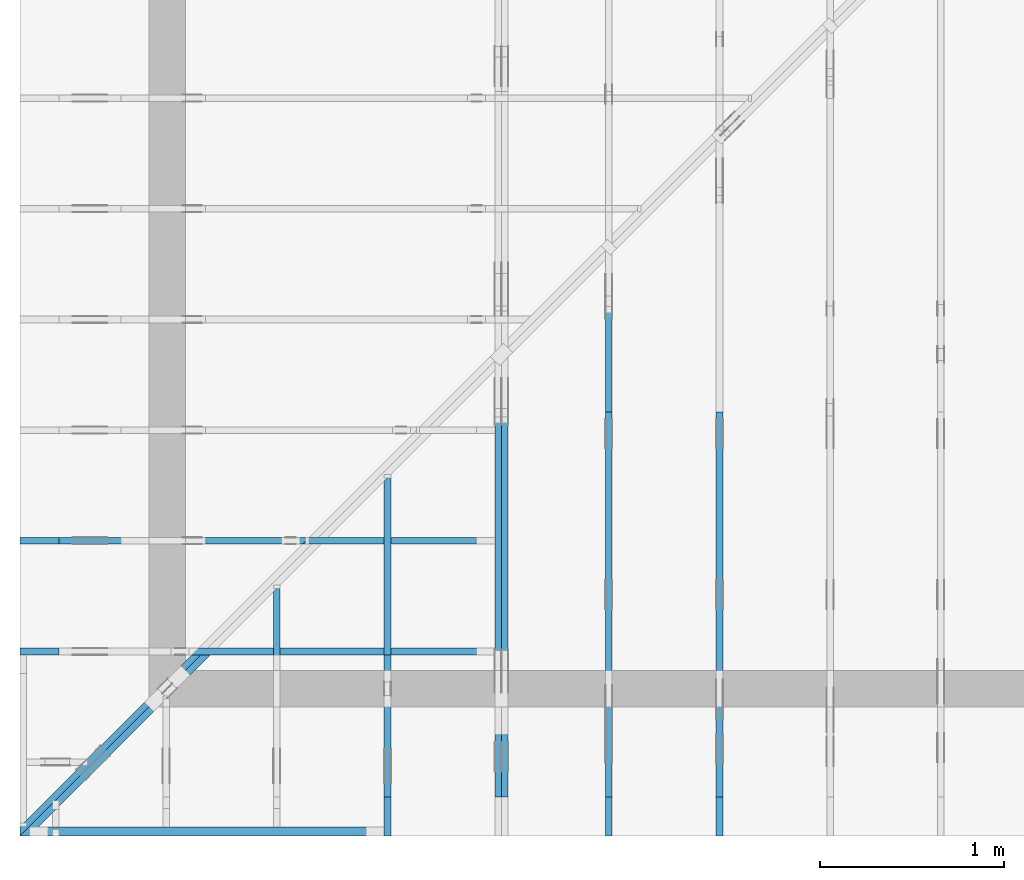
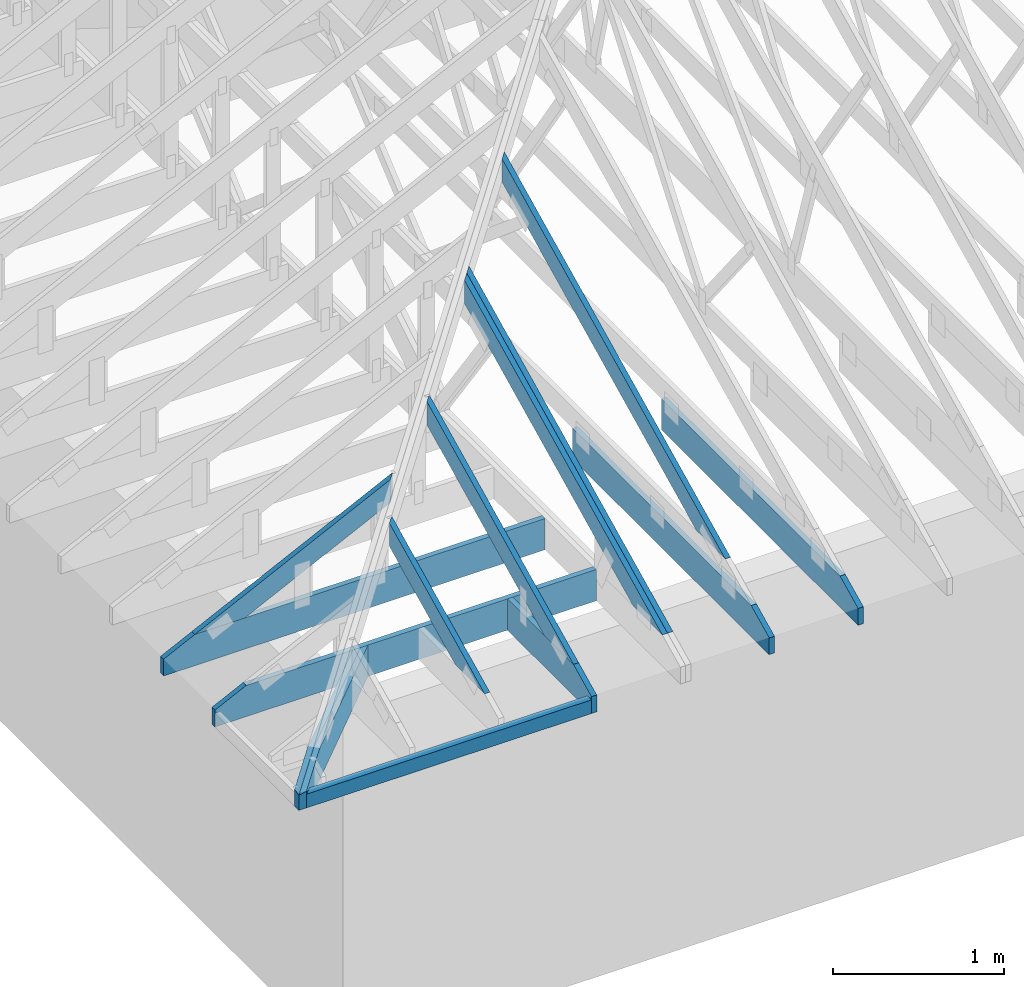
# One storey, part 2 of 159: 14 members, 9 elements without a shape of their own.
"""IFC2X3 building model written with IfcOpenShell, lengths in millimetres."""

from ifc_helpers import new_model, si_unit, frame, origin, origin_with_axes, origin_2d, place, context, project, spatial, faceted_brep, element, aggregate, save


model = new_model("IFC2X3")

# Units and contexts
model_context = context("Model", 3, precision=1e-05, world=origin())
plan_context = context("Plan", 2, precision=1e-05, world=origin_2d())
ifc_project = project(units=[si_unit("LENGTHUNIT", "METRE", prefix="MILLI"), si_unit("AREAUNIT", "SQUARE_METRE"), si_unit("VOLUMEUNIT", "CUBIC_METRE"), si_unit("SOLIDANGLEUNIT", "STERADIAN"), si_unit("PLANEANGLEUNIT", "RADIAN"), si_unit("MASSUNIT", "GRAM"), si_unit("TIMEUNIT", "SECOND"), si_unit("THERMODYNAMICTEMPERATUREUNIT", "DEGREE_CELSIUS"), si_unit("LUMINOUSINTENSITYUNIT", "LUMEN")], contexts=[model_context, plan_context])

# Site, building, storey
site_placement = place(None, origin_with_axes())
site = spatial("IfcSite", under=ifc_project, at=site_placement, CompositionType="ELEMENT")
building_placement = place(site_placement, origin_with_axes())
building = spatial("IfcBuilding", under=site, at=building_placement, Name="Plan 1", CompositionType="ELEMENT")
storey_placement = place(building_placement, origin_with_axes())
storey = spatial("IfcBuildingStorey", under=building, at=storey_placement, Name="Etasje 1", CompositionType="ELEMENT", Elevation=0.0)

# Assembly, member
assembly_1_placement = place(storey_placement, frame((-649.0883117545762, -699.9989301294845, 0.0), z_axis=(0.0, -1.0, 6.123031769111886e-17), x_axis=(1.0, 0.0, 0.0)))
assembly_1 = element("IfcElementAssembly", 1, at=assembly_1_placement, inside=storey, Name="uu1 (85)", AssemblyPlace="FACTORY", PredefinedType="TRUSS")
member_1_placement = place(assembly_1_placement, frame((1924.1105957031252, 98.00000038453275, -48.00000008178999), z_axis=(0.0, 0.0, 1.0), x_axis=(-1.0, 1.2246063538223773e-16, 0.0)))
member_1 = element("IfcMember", 2, at=member_1_placement, Name="uu1-U1", context=model_context, shape_type="Brep", body=[
    faceted_brep([(1876.110597873309, 98.000000384533, 2.2519742515214602e-06), (1924.1105957031252, 98.000000384533, 48.00000008179029), (1924.1105957031252, 3.845329956675414e-07, 48.00000008179029), (1876.1105978733092, 3.845329956675414e-07, 2.2519745925819734e-06), (2.2737367544323206e-13, 98.000000384533, 8.178999166830181e-08), (2.2737367544323206e-13, 98.000000384533, 48.00000008178999), (1924.1105957031252, 98.00000038453288, 48.00000008178999), (1876.1105957031252, 98.00000038453288, 8.178999166830181e-08), (2.2737367544323203e-13, 98.00000038453275, 8.178999166830181e-08), (1876.1105957031252, 98.00000038453275, 8.17902214179974e-08), (1876.110595703125, 3.845329956675414e-07, 8.17902214179974e-08), (2.2737367544323203e-13, 3.845329956675414e-07, 8.178999166830181e-08), (2.2543799104823847e-05, 0.0, 0.0), (2.2543799107762903e-05, -3.599185738505992e-31, 48.00000008178999), (2.2543799119764045e-05, 98.00000187990656, 48.00000092077057), (2.254379911682499e-05, 98.00000187990656, -7.348336802244504e-31), (1924.110595703125, 3.8453263095403277e-07, 48.00000008178999), (5.398778609579954e-31, 3.8453298439574193e-07, 48.00000008178999), (1.1020259538958945e-39, 3.845329814566867e-07, 8.178999166830181e-08), (1876.110595703125, 3.8453263683214327e-07, 8.178999166830181e-08), (1924.1105957031252, 98.000000384533, 48.00000008178999), (2.2737367544323206e-13, 98.000000384533, 48.00000008178999), (2.2737367544323206e-13, 3.8453276829386596e-07, 48.00000008178999), (1924.1105957031252, 3.8453276829386596e-07, 48.00000008178999)], [[[0, 1, 2, 3]], [[4, 5, 6, 7]], [[8, 9, 10, 11]], [[12, 13, 14, 15]], [[16, 17, 18, 19]], [[20, 21, 22, 23]]]),
])
aggregate(assembly_1, [member_1])

assembly_2_placement = place(storey_placement, frame((711.0222614047476, -663.9989301294845, 1.1021457184401395e-15), z_axis=(1.0, 1.6081428723391245e-16, 6.123031769111886e-17), x_axis=(-1.6081428723391245e-16, 1.0, 0.0)))
assembly_2 = element("IfcElementAssembly", 3, at=assembly_2_placement, inside=storey, Name="S11 (28)", AssemblyPlace="FACTORY", PredefinedType="TRUSS")
member_2_placement = place(assembly_2_placement, frame((240.06017447659758, 89.97845630520017, -36.000000217580876), z_axis=(0.0, 0.0, 1.0), x_axis=(0.898794046299167, 0.4383711467890774, 0.0)))
member_2 = element("IfcMember", 4, at=member_2_placement, Name="S11-O65", context=model_context, shape_type="Brep", body=[
    faceted_brep([(1278.3010010995256, 147.9999948190309, 36.000003247776476), (1206.1165771484377, 2.3277380023500882e-09, 36.000000217580805), (1166.0629072059032, 3.2351380241379957e-07, 0.0), (1238.247331156991, 147.99999514021712, 3.0301955575851025e-06), (9.693470434513074e-05, 147.99999999993207, 2.17580868877576e-07), (9.693470434513074e-05, 147.9999999999322, 36.00000021758087), (1278.3010002550168, 147.9999999999321, 36.00000021758087), (1238.247331279187, 147.999999999932, 2.17580868877576e-07), (1.594481932443159e-05, 148.00000000209985, 2.1758086887757795e-07), (1238.2473303979443, 148.00000000209985, 2.1758102051413083e-07), (1166.0629050439404, 0.0, 2.1758101167438024e-07), (303.44502326903785, 0.0, 2.1758090603764635e-07), (303.4450252214778, 1.1349783335390384e-09, 2.17580868877576e-07), (303.4450252214778, 1.1349783335390384e-09, 36.00000021758087), (5.3508346482544766e-05, 148.00000154207527, 36.00000021758087), (5.3508346482544766e-05, 148.00000154207524, 2.17580868877576e-07), (1206.1165762671362, 2.2746174269175835e-09, 36.00000021758087), (303.4450484045873, 2.2747832395108486e-09, 36.00000021758087), (303.4450484045873, 2.2747810352194118e-09, 2.17580868877576e-07), (1166.0629072913064, 2.2746225801227748e-09, 2.17580868877576e-07), (1278.3010025024416, 148.00000000232774, 36.00000021758087), (0.0, 148.00000000232774, 36.00000021758087), (303.445007324219, 1.1350778095220448e-09, 36.00000021758087), (1206.1165771484377, 1.1350778095220448e-09, 36.00000021758087)], [[[0, 1, 2, 3]], [[4, 5, 6, 7]], [[8, 9, 10, 11]], [[12, 13, 14, 15]], [[16, 17, 18, 19]], [[20, 21, 22, 23]]]),
])
aggregate(assembly_2, [member_2])

# Assembly, members
assembly_3_placement = place(storey_placement, frame((1311.0222614047498, -699.9989301294839, 1.1021457184401395e-15), z_axis=(1.0, -6.123031769111886e-17, 6.123031769111886e-17), x_axis=(6.123031769111886e-17, 1.0, 0.0)))
assembly_3 = element("IfcElementAssembly", 5, at=assembly_3_placement, inside=storey, Name="S12 (27)", AssemblyPlace="FACTORY", PredefinedType="TRUSS")
member_3_placement = place(assembly_3_placement, frame((276.06018082080396, 89.97845939889237, -36.00000021758392), z_axis=(0.0, 0.0, 1.0), x_axis=(0.898794046299167, 0.4383711467890774, 0.0)))
member_3 = element("IfcMember", 6, at=member_3_placement, Name="S12-O56", context=model_context, shape_type="Brep", body=[
    faceted_brep([(1945.8621583260756, 147.99999481908407, 36.00000324777977), (1873.677734375, 2.3747475097479764e-09, 36.00000021758376), (1833.6240644324685, 3.2355615076085087e-07, -3.410605131648481e-13), (1905.808488383544, 147.99999514026558, 3.0301958986456157e-06), (9.693470428828732e-05, 147.9999999999792, 2.175839171059124e-07), (9.693470428828732e-05, 147.99999999997908, 36.00000021758392), (1945.8621574815793, 147.9999999999794, 36.00000021758392), (1905.8084885057492, 147.9999999999795, 2.175839171059124e-07), (1.5944795677569346e-05, 148.00000000099197, 2.1758391710591436e-07), (1905.808487624483, 148.00000000099197, 2.1758415049243072e-07), (1833.6240622704795, 0.0, 2.1758414165268013e-07), (303.44496223385806, 0.0, 2.175839542659753e-07), (303.44501816315744, 1.65989888500917e-09, 2.175839171059124e-07), (303.44501816315744, 1.65989888500917e-09, 36.00000021758392), (4.645002616854299e-05, 148.00000154260016, 36.00000021758392), (4.645002616854299e-05, 148.00000154260016, 2.175839171059124e-07), (1873.677733493715, 2.3561247410074944e-09, 36.00000021758392), (303.4449873694475, 2.356413178557177e-09, 36.00000021758392), (303.4449873694475, 2.35641097426574e-09, 2.175839171059124e-07), (1833.624064517885, 2.3561298942126856e-09, 2.175839171059124e-07), (1945.862159729004, 148.0000000023748, 36.00000021758392), (0.0, 148.0000000023748, 36.00000021758392), (303.4450683593751, 1.659969939282746e-09, 36.00000021758392), (1873.677734375, 1.659969939282746e-09, 36.00000021758392)], [[[0, 1, 2, 3]], [[4, 5, 6, 7]], [[8, 9, 10, 11]], [[12, 13, 14, 15]], [[16, 17, 18, 19]], [[20, 21, 22, 23]]]),
])
member_4_placement = place(assembly_3_placement, frame((982.00634765625, 223.0, -36.0), z_axis=(0.0, 0.0, 1.0), x_axis=(-1.0, 1.2246063538223773e-16, 0.0)))
member_4 = element("IfcMember", 7, at=member_4_placement, Name="S12-U21", context=model_context, shape_type="Brep", body=[
    faceted_brep([(982.00634765625, 223.00000000001467, 36.0), (0.0, 223.00000000001467, 36.0), (0.0, 0.0, 36.0), (770.8250579833984, 0.0, 36.0), (982.006318893953, 102.99998474121105, 36.0), (0.0, 223.00000000001467, 0.0), (982.00634765625, 223.00000000001467, 1.20257121283375e-13), (982.006318893953, 102.99998474121105, 1.2025711776112584e-13), (770.8250579833984, 0.0, 9.439572636919721e-14), (0.0, 0.0, 0.0), (1.61055054377357e-05, 0.0, 0.0), (1.6105505439939992e-05, -2.6993892992798474e-31, 36.0), (1.6105505467248714e-05, 223.0, 36.0), (1.6105505465044423e-05, 223.0, -1.6721217180559947e-30), (770.8250519745052, -1.4159359023153358e-13, 1.3890631406147823e-29), (770.8250519745052, -1.393892987946533e-13, 36.0), (1.61055054377357e-05, 2.204286696927529e-15, 36.0), (1.61055054377357e-05, -4.739952749857793e-21, 2.9022881271468516e-37), (982.0063188939536, 102.99998597132787, 1.5480697785024754e-29), (982.0063188939536, 102.99998597132787, 36.0), (770.8250519745053, -5.684341886080802e-14, 36.0), (770.8250519745053, -5.684341886080802e-14, 1.1601225646455601e-29), (982.0062942062657, 223.00000000001467, -3.272759518476984e-21), (982.0062942062657, 223.00000000001467, 36.0), (982.0062942062657, 102.9999859713281, 36.0), (982.0062942062657, 102.9999859713281, -1.5116349691744716e-21), (1.61055054377357e-05, 223.0, 0.0), (1.61055054377357e-05, 223.0, 36.0), (982.00634765625, 223.00000000001475, 36.0), (982.00634765625, 223.00000000001478, 6.310887241768095e-30)], [[[0, 1, 2, 3, 4]], [[5, 6, 7, 8, 9]], [[10, 11, 12, 13]], [[14, 15, 16, 17]], [[18, 19, 20, 21]], [[22, 23, 24, 25]], [[26, 27, 28, 29]]]),
])
aggregate(assembly_3, [member_3, member_4])

# Assembly, member
assembly_4_placement = place(storey_placement, frame((-700.000000000007, 282.0074014212605, 1.1021457184401395e-15), z_axis=(0.0, -1.0, 6.123031769111886e-17), x_axis=(1.0, 0.0, 0.0)))
assembly_4 = element("IfcElementAssembly", 8, at=assembly_4_placement, inside=storey, Name="S8 (22)", AssemblyPlace="FACTORY", PredefinedType="TRUSS")
member_5_placement = place(assembly_4_placement, frame((2575.022261404756, 223.00000000093104, -36.0), z_axis=(0.0, 0.0, 1.0), x_axis=(-1.0, 1.2246063538223773e-16, 0.0)))
member_5 = element("IfcMember", 9, at=member_5_placement, Name="S8-U11", context=model_context, shape_type="Brep", body=[
    faceted_brep([(2575.022261404767, 223.00000000093135, 36.0), (4.4607881136471406e-05, 223.00000000093135, 36.0), (4.4607881136471406e-05, 9.310383575211745e-10, 36.0), (2363.8409717319046, 9.310383575211745e-10, 36.0), (2575.0222614047602, 103.00000000093135, 36.0), (4.4607881136471406e-05, 223.00000000093135, 5.462709467027625e-21), (2575.022261404767, 223.00000000093135, 3.1533886225503443e-13), (2575.0222614047602, 103.00000000093135, 3.1533886225503357e-13), (2363.8409717319046, 9.310383575211745e-10, 2.8947746734085526e-13), (4.4607881136471406e-05, 9.310383575211745e-10, 5.462709467027625e-21), (1.1401554882727804e-25, 9.310383575211745e-10, -6.981208276421509e-42), (2.2042914369942947e-15, 9.310383575211745e-10, 36.0), (2.9513013127233304e-14, 223.00000000093104, 36.0), (2.730872169035303e-14, 223.00000000093104, -1.6721217048386645e-30), (2363.8409657211487, 5.200890442812092e-13, -3.184521740901289e-29), (2363.8409657211487, 5.222933357180895e-13, 36.0), (8.67712118026388e-28, 9.310405618126114e-10, 36.0), (0.0, 9.310383575211745e-10, 0.0), (2575.0222614047602, 103.00000000064097, -5.048709793414476e-29), (2575.0222614047602, 103.00000000064097, 36.0), (2363.840965721148, 4.547473508864641e-13, 36.0), (2363.840965721148, 4.547473508864641e-13, -3.7865323450608567e-29), (2575.0222614047543, 223.00000000093135, -7.825500179792437e-28), (2575.0222614047543, 223.00000000093135, 36.0), (2575.0222614047543, 103.00000000064031, 36.0), (2575.0222614047543, 103.00000000064031, -3.534096855390133e-28), (0.0, 223.00000000093104, 0.0), (0.0, 223.00000000093104, 36.0), (2575.022261404767, 223.00000000093144, 36.0), (2575.022261404767, 223.00000000093146, 6.310887241768095e-30)], [[[0, 1, 2, 3, 4]], [[5, 6, 7, 8, 9]], [[10, 11, 12, 13]], [[14, 15, 16, 17]], [[18, 19, 20, 21]], [[22, 23, 24, 25]], [[26, 27, 28, 29]]]),
])
aggregate(assembly_4, [member_5])

# Assembly, members
assembly_5_placement = place(storey_placement, frame((-700.000000000007, 882.0074014212605, 1.1021457184401395e-15), z_axis=(0.0, -1.0, 6.123031769111886e-17), x_axis=(1.0, 0.0, 0.0)))
assembly_5 = element("IfcElementAssembly", 10, at=assembly_5_placement, inside=storey, Name="S7 (20)", AssemblyPlace="FACTORY", PredefinedType="TRUSS")
member_6_placement = place(assembly_5_placement, frame((276.0601750510328, 89.97845622840634, -36.00000021757322), z_axis=(0.0, 0.0, 1.0), x_axis=(0.898794046299167, 0.4383711467890774, 0.0)))
member_6 = element("IfcMember", 11, at=member_6_placement, Name="S7-O62", context=model_context, shape_type="Brep", body=[
    faceted_brep([(1508.5918758480614, 148.000000830815, 2.253357479276019e-06), (1468.538208850715, 147.99999513788663, 35.999997187391386), (1396.353784899615, 3.211893613297434e-07, 36.000000217573415), (1436.4074548421563, -1.1368683772161603e-13, 1.1368683772161603e-13), (6.310887241768095e-30, 148.00000032211383, 2.1757321633231183e-07), (-7.888609052210118e-31, 148.00000032211372, 36.000000217573216), (1468.5382080078125, 148.00000032211364, 36.000000217573216), (1508.5918769836428, 148.00000032211375, 2.1757321633231183e-07), (303.445024738843, 3.219727346959189e-07, 2.1757321633231186e-07), (303.445024738843, 3.219727346959189e-07, 36.000000217573216), (5.3025711736154335e-05, 148.000001862913, 36.000000217573216), (5.3025711736154335e-05, 148.000001862913, 2.1757321633231186e-07), (1436.4074547567068, 3.2116058288785024e-07, 2.1757321633231186e-07), (1396.3537857808765, 3.2116047254555165e-07, 36.000000217573216), (303.4450524129566, 3.211606733029985e-07, 36.000000217573216), (303.4450524129566, 3.2116079100279374e-07, 2.1757321633231186e-07), (1468.5382102536184, 148.00000032118953, 36.000000217573216), (2.5133989367986942e-05, 148.00000032118953, 36.000000217573216), (303.4449714230521, 3.219728057501925e-07, 36.000000217573216), (1396.3537848996145, 3.219728057501925e-07, 36.000000217573216), (8.098991878568995e-05, 148.00000032212108, 2.1757321633232178e-07), (1508.5918778649188, 148.00000032212108, 2.1757340107543176e-07), (1436.407452510915, 3.2211346479016356e-07, 2.1757339223568115e-07), (303.4450272789813, 3.2211346479016356e-07, 2.175732534923827e-07)], [[[0, 1, 2, 3]], [[4, 5, 6, 7]], [[8, 9, 10, 11]], [[12, 13, 14, 15]], [[16, 17, 18, 19]], [[20, 21, 22, 23]]]),
])
member_7_placement = place(assembly_5_placement, frame((2575.022261404756, 223.00000000093104, -36.0), z_axis=(0.0, 0.0, 1.0), x_axis=(-1.0, 1.2246063538223773e-16, 0.0)))
member_7 = element("IfcMember", 12, at=member_7_placement, Name="S7-U11", context=model_context, shape_type="Brep", body=[
    faceted_brep([(2575.022261404767, 223.00000000093135, 36.0), (4.4607881136471406e-05, 223.00000000093135, 36.0), (4.4607881136471406e-05, 9.310383575211745e-10, 36.0), (2363.8409717319046, 9.310383575211745e-10, 36.0), (2575.0222614047602, 103.00000000093135, 36.0), (4.4607881136471406e-05, 223.00000000093135, 5.462709467027625e-21), (2575.022261404767, 223.00000000093135, 3.1533886225503443e-13), (2575.0222614047602, 103.00000000093135, 3.1533886225503357e-13), (2363.8409717319046, 9.310383575211745e-10, 2.8947746734085526e-13), (4.4607881136471406e-05, 9.310383575211745e-10, 5.462709467027625e-21), (1.1401554882727804e-25, 9.310383575211745e-10, -6.981208276421509e-42), (2.2042914369942947e-15, 9.310383575211745e-10, 36.0), (2.9513013127233304e-14, 223.00000000093104, 36.0), (2.730872169035303e-14, 223.00000000093104, -1.6721217048386645e-30), (2363.8409657211487, 5.200890442812092e-13, -3.184521740901289e-29), (2363.8409657211487, 5.222933357180895e-13, 36.0), (8.67712118026388e-28, 9.310405618126114e-10, 36.0), (0.0, 9.310383575211745e-10, 0.0), (2575.0222614047602, 103.00000000064097, -5.048709793414476e-29), (2575.0222614047602, 103.00000000064097, 36.0), (2363.840965721148, 4.547473508864641e-13, 36.0), (2363.840965721148, 4.547473508864641e-13, -3.7865323450608567e-29), (2575.0222614047543, 223.00000000093135, -7.825500179792437e-28), (2575.0222614047543, 223.00000000093135, 36.0), (2575.0222614047543, 103.00000000064031, 36.0), (2575.0222614047543, 103.00000000064031, -3.534096855390133e-28), (0.0, 223.00000000093104, 0.0), (0.0, 223.00000000093104, 36.0), (2575.022261404767, 223.00000000093144, 36.0), (2575.022261404767, 223.00000000093146, 6.310887241768095e-30)], [[[0, 1, 2, 3, 4]], [[5, 6, 7, 8, 9]], [[10, 11, 12, 13]], [[14, 15, 16, 17]], [[18, 19, 20, 21]], [[22, 23, 24, 25]], [[26, 27, 28, 29]]]),
])
aggregate(assembly_5, [member_6, member_7])

assembly_6_placement = place(storey_placement, frame((-674.5441558772914, -725.4547742521996, 2.204291436880279e-15), z_axis=(0.7071067811865475, -0.7071067811865476, 6.123031769111886e-17), x_axis=(0.7071067811865476, 0.7071067811865475, 0.0)))
assembly_6 = element("IfcElementAssembly", 13, at=assembly_6_placement, inside=storey, Name="GR1 (8)", AssemblyPlace="FACTORY", PredefinedType="TRUSS")
member_8_placement = place(assembly_6_placement, frame((1424.7667236328116, 223.00000146033642, -36.00000106987069), z_axis=(0.0, 0.0, 1.0), x_axis=(-1.0, -3.216285744678249e-16, 0.0)))
member_8 = element("IfcMember", 14, at=member_8_placement, Name="GR1-U18.1", context=model_context, shape_type="Brep", body=[
    faceted_brep([(36.0000522871483, 1.4603364482436182e-06, 1.9184653865522705e-13), (5.121749859071656e-05, 1.4603364206777771e-06, 36.00000106987091), (5.121749861913827e-05, 223.00000146033645, 36.00000106987071), (36.00005228714829, 223.00000146033645, 2.842170943040401e-14), (1090.1112572721859, 1.4603362204342013e-06, 1.0698706915945877e-06), (1090.1112572721859, 1.4603362226384927e-06, 36.00000106987069), (5.12174983668956e-05, 1.460336422882059e-06, 36.00000106987069), (36.00005121749837, 1.4603364140648933e-06, 1.0698706915945877e-06), (36.00005121727622, 223.00000146033642, 1.069870696003177e-06), (1424.766774850089, 223.00000146033642, 1.0698708660724322e-06), (1424.766042428214, 115.4154067337739, 1.0698708660723424e-06), (1090.111257271964, 1.4603360796172637e-06, 1.069870825090305e-06), (36.00005121727645, 1.4603360796172637e-06, 1.069870696003177e-06), (1424.7667247025825, 223.00000146010532, 1.1300471669528633e-10), (1388.7667236328157, 223.00000146010532, 36.00000106987375), (1388.7667236328157, 103.00000146010534, 36.00000106987375), (1424.7660368660113, 115.41540864088924, 0.0006878366840510353), (5.121727622281469e-05, 223.00000146033605, 36.00000106987069), (1388.7667748500887, 223.00000146033597, 36.00000106987069), (1424.7667748500887, 223.00000146033597, 1.0698706915945877e-06), (36.00005121727622, 223.00000146033605, 1.0698706915945877e-06), (1424.7660355374512, 115.41540889855975, 0.0006891652379863444), (1388.7667219993955, 103.00000089677394, 36.000002519730174), (1090.1112669253732, -2.2737367544323206e-13, 36.000002519730145), (1090.1112669253732, -2.2737367544323206e-13, 1.0698937273900808e-06), (1388.7667236328125, 223.00000146010532, 36.00000106987069), (0.0, 223.00000146010532, 36.00000106987069), (0.0, 1.4601053521801077e-06, 36.00000106987069), (1090.1112670898438, 1.4601053521801077e-06, 36.00000106987069), (1388.7667236328125, 103.00000146010534, 36.00000106987069)], [[[0, 1, 2, 3]], [[4, 5, 6, 7]], [[8, 9, 10, 11, 12]], [[13, 14, 15, 16]], [[17, 18, 19, 20]], [[21, 22, 23, 24]], [[25, 26, 27, 28, 29]]]),
])
member_9_placement = place(assembly_6_placement, frame((1388.7666724155354, 223.00000338444795, -72.00000132855524), z_axis=(0.0, 0.0, 1.0), x_axis=(-1.0, -3.216285744678249e-16, 0.0)))
member_9 = element("IfcMember", 15, at=member_9_placement, Name="GR1-U18.1", context=model_context, shape_type="Brep", body=[
    faceted_brep([(36.00000106976846, 3.3844475924350603e-06, 2.5880326859351044e-07), (2.3092638912203256e-13, 3.384447580856431e-06, 36.00000132855513), (2.4868995751603507e-14, 223.00000338444758, 36.00000132855527), (36.00000106976839, 223.00000338444758, 2.5880326859351044e-07), (1054.1112060546877, 3.3844477282862523e-06, 1.3285552427078073e-06), (1054.1112060546877, 3.384447754471361e-06, 36.00000132855524), (2.2737367544323206e-13, 3.384447948102053e-06, 36.00000132855524), (36.00000000000023, 3.38444791530407e-06, 1.3285552427078073e-06), (36.000000000011596, 223.00000338444792, 1.3285552471163902e-06), (1352.766723632824, 223.00000338444792, 1.3285554083684798e-06), (1352.766723632824, 103.00000338444794, 1.3285554083684798e-06), (1054.111206054699, 3.3844476092781406e-06, 1.3285553717949354e-06), (36.000000000011596, 3.3844476092781406e-06, 1.3285552471163902e-06), (1352.7666710869821, 223.00000554923406, -1.1368683772161603e-13), (1388.7666724155504, 223.00000554923406, 36.00000132856792), (1388.7659843201745, 115.41541082267156, 35.99931323319231), (1352.7666710869821, 103.00000364188543, -1.1368683772161603e-13), (1.1596057447604835e-11, 223.00000338444718, 36.00000132855524), (1388.766723632824, 223.0000033844471, 36.00000132855524), (1352.766723632824, 223.0000033844471, 1.3285552427078073e-06), (36.000000000011596, 223.00000338444718, 1.3285552427078073e-06), (1388.7659859535934, 115.41541138600286, 35.99931468304743), (1054.1112101290062, -1.7053025658242404e-13, 36.00000132855522), (1054.1112101290062, -2.2737367544323206e-13, 1.3285552427078073e-06), (1352.7666724155379, 103.00000338421711, 1.3285552427078073e-06), (1388.7667236328125, 223.00000338443294, 36.00000132855524), (0.0, 223.00000338443294, 36.00000132855524), (2.2737367544323206e-13, 3.384447580856431e-06, 36.00000132855524), (1054.1112060546875, 3.384447580856431e-06, 36.00000132855524), (1388.7659912109375, 115.41540865788507, 36.00000132855524)], [[[0, 1, 2, 3]], [[4, 5, 6, 7]], [[8, 9, 10, 11, 12]], [[13, 14, 15, 16]], [[17, 18, 19, 20]], [[21, 22, 23, 24]], [[25, 26, 27, 28, 29]]]),
])
aggregate(assembly_6, [member_8, member_9])

# Assembly, member
assembly_7_placement = place(storey_placement, frame((3075.02226140475, 9699.999999999993, 1.1021457184401395e-15), z_axis=(-1.0, 1.836909530733566e-16, 6.123031769111886e-17), x_axis=(-1.836909530733566e-16, -1.0, 0.0)))
assembly_7 = element("IfcElementAssembly", 16, at=assembly_7_placement, inside=storey, Name="V3 (4)", AssemblyPlace="FACTORY", PredefinedType="TRUSS")
member_10_placement = place(assembly_7_placement, frame((8099.998930129453, 0.0, -36.0), z_axis=(0.0, 0.0, 1.0), x_axis=(1.0, 0.0, 0.0)))
member_10 = element("IfcMember", 17, at=member_10_placement, Name="V3-U14", context=model_context, shape_type="Brep", body=[
    faceted_brep([(2088.8184526830473, 223.0, 36.0), (9.330804732599063e-05, 223.0, 36.0), (9.330804732599063e-05, 0.0, 36.0), (2300.0000933080473, 0.0, 36.0), (2300.0000933080473, 120.00001525878906, 36.0), (9.330804732599063e-05, 223.0, 1.142656276181672e-20), (2088.8184526830473, 223.0, 2.5579803491370865e-13), (2300.0000933080473, 120.00001525878906, 2.8165947280570954e-13), (2300.0000933080473, 0.0, 2.8165947280570954e-13), (9.330804732599063e-05, 0.0, 1.142656276181672e-20), (2088.8187043173557, 223.0000000000001, 1.262177448353619e-29), (2088.8187043173557, 223.0000000000001, 36.0), (2299.9999712377276, 120.00001402830935, 36.0), (2299.9999712377276, 120.00001402830935, 1.262177448353619e-29), (2.091837814077735e-11, 223.0, 0.0), (2.091837814077735e-11, 223.0, 36.0), (2088.8187043173557, 222.99999999999986, 36.0), (2088.8187043173557, 222.99999999999986, -7.888609052210118e-30), (0.0, 0.0, 0.0), (2.204291436880279e-15, -2.068182698939301e-28, 36.0), (2.0925242604202116e-11, 223.0, 36.0), (2.0923038312765235e-11, 223.0, -2.8534381131350165e-31), (2300.000000000001, -4.224891920687203e-13, 2.586914745143188e-29), (2300.000000000001, -4.2028490063184003e-13, 36.0), (4.049083948919771e-31, 2.204291436880279e-15, 36.0), (0.0, 0.0, 0.0), (2299.999999999869, 120.00001402830927, 1.761115057728101e-21), (2299.999999999869, 120.00001402830927, 36.0), (2299.999999999869, 0.0, 36.0), (2299.999999999869, 0.0, -8.077935669463161e-27)], [[[0, 1, 2, 3, 4]], [[5, 6, 7, 8, 9]], [[10, 11, 12, 13]], [[14, 15, 16, 17]], [[18, 19, 20, 21]], [[22, 23, 24, 25]], [[26, 27, 28, 29]]]),
])
aggregate(assembly_7, [member_10])

# Assembly, members
assembly_8_placement = place(storey_placement, frame((2475.02226140475, 9699.999999999993, 1.1021457184401395e-15), z_axis=(-1.0, 1.836909530733566e-16, 6.123031769111886e-17), x_axis=(-1.836909530733566e-16, -1.0, 0.0)))
assembly_8 = element("IfcElementAssembly", 18, at=assembly_8_placement, inside=storey, Name="V2 (3)", AssemblyPlace="FACTORY", PredefinedType="TRUSS")
member_11_placement = place(assembly_8_placement, frame((7175.009320381433, 1528.2674415557449, -36.00000021758204), z_axis=(0.0, 0.0, 1.0), x_axis=(0.8987940462991668, -0.4383711467890778, 0.0)))
member_11 = element("IfcMember", 19, at=member_11_placement, Name="V2-O39/", context=model_context, shape_type="Brep", body=[
    faceted_brep([(112.23821195363509, 6.724300874338951e-06, 36.0000032477941), (40.053788002536756, 148.00000154099877, 36.00000021758203), (0.00011806000386016535, 148.0000012198061, -2.842170943040401e-14), (72.18454201110129, 6.403107812857911e-06, 3.0302110403113147e-06), (2639.9261993911887, 1.5417058119175736e-06, 2.1758204127309e-07), (2639.9261993911887, 1.541705814121865e-06, 36.00000021758204), (112.23821110993958, 1.5417062784352806e-06, 36.00000021758204), (72.1845421341095, 1.541706283588486e-06, 2.1758204127309e-07), (0.0001181454263132764, 148.00000154099962, 2.1758204127309e-07), (40.053787121256384, 148.00000154099962, 36.00000021758204), (2943.371211895427, 148.0000015409988, 36.00000021758204), (2943.371211895427, 148.0000015409988, 2.1758204127309e-07), (2943.3710937499995, 148.00000154093868, 2.1758204127309e-07), (2943.3710937499995, 148.00000154093868, 36.00000021758204), (2639.9261220368694, -1.5916157281026244e-12, 36.00000021758204), (2639.9261220368694, -1.5916157281026244e-12, 2.1758204127309e-07), (2943.371170815036, 148.0000015409396, 36.00000021758204), (40.05378800253675, 148.0000015409396, 36.00000021758204), (112.23821335654065, 1.5409987099701539e-06, 36.00000021758204), (2639.926102455661, 1.5409987099701539e-06, 36.00000021758204), (0.0, 148.00000154099962, 2.1758204127309e-07), (2943.371093749999, 148.00000154099962, 2.175824017201843e-07), (2639.9261169433585, 1.5409405023092404e-06, 2.1758236456011964e-07), (72.18457031250091, 1.5409405023092404e-06, 2.1758205011285834e-07)], [[[0, 1, 2, 3]], [[4, 5, 6, 7]], [[8, 9, 10, 11]], [[12, 13, 14, 15]], [[16, 17, 18, 19]], [[20, 21, 22, 23]]]),
])
member_12_placement = place(assembly_8_placement, frame((8099.998930129474, 0.0, -36.0), z_axis=(0.0, 0.0, 1.0), x_axis=(1.0, 0.0, 0.0)))
member_12 = element("IfcMember", 20, at=member_12_placement, Name="V2-U14", context=model_context, shape_type="Brep", body=[
    faceted_brep([(2088.8184526830264, 223.0, 36.0), (9.330802640761249e-05, 223.0, 36.0), (9.330802640761249e-05, 0.0, 36.0), (2300.0000933080264, 0.0, 36.0), (2300.0000933080264, 120.00001525878906, 36.0), (9.330802640761249e-05, 223.0, 1.1426560200138842e-20), (2088.8184526830264, 223.0, 2.557980349137061e-13), (2300.0000933080264, 120.00001525878906, 2.8165947280570696e-13), (2300.0000933080264, 0.0, 2.8165947280570696e-13), (9.330802640761249e-05, 0.0, 1.1426560200138842e-20), (2088.8187043173357, 223.00000000000034, 2.524354896707238e-29), (2088.8187043173357, 223.00000000000034, 36.0), (2299.999971237707, 120.00001402830958, 36.0), (2299.999971237707, 120.00001402830958, 2.524354896707238e-29), (0.0, 223.0, 0.0), (-1.3496946496399237e-31, 223.0, 36.0), (2088.818704317335, 222.99999999999986, 36.0), (2088.818704317335, 222.99999999999986, -7.888609052210118e-30), (0.0, 0.0, 0.0), (2.204291436880279e-15, -2.6993892992798474e-31, 36.0), (2.951301312711929e-14, 223.0, 36.0), (2.7308721690239013e-14, 223.0, -1.6721217048316832e-30), (2300.0, -4.2248919206872015e-13, 2.586914745143187e-29), (2300.0, -4.202849006318399e-13, 36.0), (4.049083948919771e-31, 2.204291436880279e-15, 36.0), (0.0, 0.0, 0.0), (2299.999999999868, 120.00001402830924, 1.7611162946620003e-21), (2299.999999999868, 120.00001402830924, 36.0), (2299.999999999868, 0.0, 36.0), (2299.999999999868, 0.0, -8.077935669463161e-27)], [[[0, 1, 2, 3, 4]], [[5, 6, 7, 8, 9]], [[10, 11, 12, 13]], [[14, 15, 16, 17]], [[18, 19, 20, 21]], [[22, 23, 24, 25]], [[26, 27, 28, 29]]]),
])
aggregate(assembly_8, [member_11, member_12])

assembly_9_placement = place(storey_placement, frame((1875.0222614047502, 9699.999999999993, 0.0), z_axis=(-1.0, 1.836909530733566e-16, 6.123031769111886e-17), x_axis=(-1.836909530733566e-16, -1.0, 0.0)))
assembly_9 = element("IfcElementAssembly", 21, at=assembly_9_placement, inside=storey, Name="V1 (2)", AssemblyPlace="FACTORY", PredefinedType="TRUSS")
member_13_placement = place(assembly_9_placement, frame((7775.0094245502205, 1235.6278376094833, -36.000003030209996), z_axis=(0.0, 0.0, 1.0), x_axis=(0.8987940462991668, -0.4383711467890778, 0.0)))
member_13 = element("IfcMember", 22, at=member_13_placement, Name="V1-O43.1", context=model_context, shape_type="Brep", body=[
    faceted_brep([(112.23809529653683, 1.863785659139694e-06, 36.00000324779227), (40.05367134543741, 147.99999668048343, 36.00000021758246), (1.4029037629370578e-06, 147.99999635929092, -2.1316282072803006e-14), (72.184425354003, 1.542593969006134e-06, 3.030209995813493e-06), (2.2466056179837324e-06, 148.00000154187546, 3.030209995813493e-06), (40.053671222436606, 148.00000154187637, 36.000003030209996), (2613.4233420903574, 148.00000154187737, 36.000003030209996), (2613.4233420903574, 148.00000154187646, 3.030209995813493e-06), (2613.4233010099715, 148.0000015409405, 36.000003030209996), (40.05367210371969, 148.0000015409405, 36.000003030209996), (112.2380974577236, 1.5418618204421364e-06, 36.000003030209996), (2309.9782326505965, 1.5418618204421364e-06, 36.000003030209996), (2309.978329586119, 1.5425762290834011e-06, 3.030209995813493e-06), (2309.978329586119, 1.5425753040294224e-06, 36.000003030209996), (112.23809521111889, 1.5425757077344207e-06, 36.000003030209996), (72.18442623528881, 1.5425766401458962e-06, 3.030209995813493e-06), (2613.4232744062806, 148.00000154093868, 3.030209995813493e-06), (2613.4232744062806, 148.00000154093868, 36.000003030209996), (2309.9783026931505, -1.5916157281026244e-12, 36.000003030209996), (2309.9783026931505, -1.5916157281026244e-12, 3.030209995813493e-06), (0.0, 148.00000154259396, 3.030209995813493e-06), (2613.423194885253, 148.00000154259396, 3.0302103158549583e-06), (2309.978370666505, 1.5416080714203417e-06, 3.0302102786949122e-06), (72.184425354003, 1.5416080714203417e-06, 3.0302100046532438e-06)], [[[0, 1, 2, 3]], [[4, 5, 6, 7]], [[8, 9, 10, 11]], [[12, 13, 14, 15]], [[16, 17, 18, 19]], [[20, 21, 22, 23]]]),
])
member_14_placement = place(assembly_9_placement, frame((7739.009328812599, 1253.186257492212, -72.00000021755147), z_axis=(0.0, 0.0, 1.0), x_axis=(0.8987940462991668, -0.4383711467890778, 0.0)))
member_14 = element("IfcMember", 23, at=member_14_placement, Name="V1-O43.1", context=model_context, shape_type="Brep", body=[
    faceted_brep([(112.23820257272291, 6.725201274093706e-06, 36.00000324770847), (40.0537786215755, 148.0000015418755, 36.00000021755144), (0.00010867901439581829, 148.00000122067019, -4.263256414560601e-14), (72.18453263016127, 6.40399611562259e-06, 3.0301565701051913e-06), (2350.0321470414747, 1.5425935319974188e-06, 2.175514737245976e-07), (2350.0321470414747, 1.5425935342017102e-06, 36.000000217551474), (112.23820172897285, 1.5425939452642129e-06, 36.000000217551474), (72.18453275314278, 1.542593950417418e-06, 2.175514737245976e-07), (0.00010876445867324946, 148.00000154189001, 2.175514737245976e-07), (40.05377774028875, 148.00000154189001, 36.000000217551474), (2653.4771595457096, 148.00000154188984, 36.000000217551474), (2653.4771595457096, 148.00000154188984, 2.175514737245976e-07), (2653.4770507812505, 148.00000154093846, 2.175514737245976e-07), (2653.4770507812505, 148.00000154093846, 36.000000217551474), (2350.0320790681203, -1.8189894035458565e-12, 36.000000217551474), (2350.0320790681203, -1.8189894035458565e-12, 2.175514737245976e-07), (2653.4771184653255, 148.0000015409405, 36.000000217551474), (40.053778621575475, 148.0000015409405, 36.000000217551474), (112.23820397557938, 1.541875462862663e-06, 36.000000217551474), (2350.0320501059505, 1.541875462862663e-06, 36.000000217551474), (0.0, 148.00000154189001, 2.175514737245976e-07), (2653.47705078125, 148.00000154189001, 2.175517986710832e-07), (2350.0320739746094, 1.5409395928145386e-06, 2.1755176151101855e-07), (72.1845703125, 1.5409395928145386e-06, 2.1755148256436594e-07)], [[[0, 1, 2, 3]], [[4, 5, 6, 7]], [[8, 9, 10, 11]], [[12, 13, 14, 15]], [[16, 17, 18, 19]], [[20, 21, 22, 23]]]),
])
aggregate(assembly_9, [member_13, member_14])

save(model, "model.ifc")
